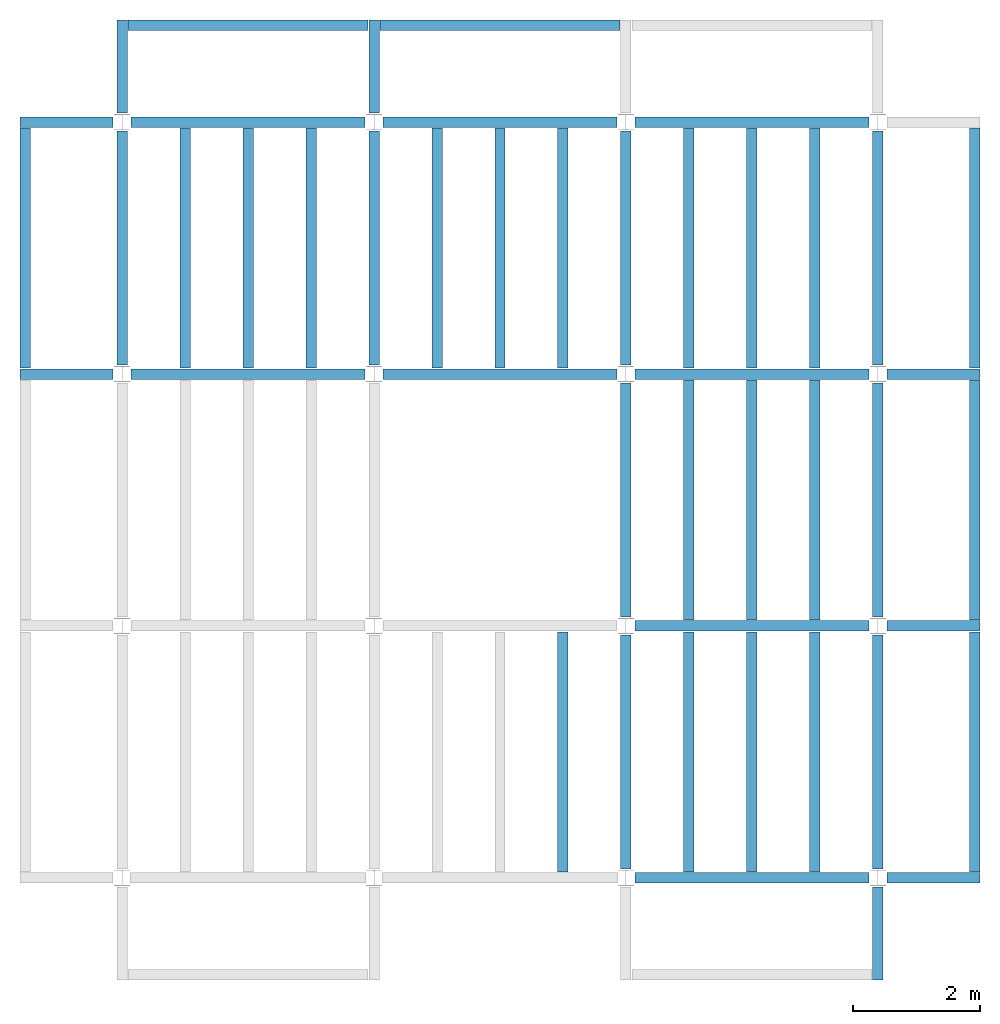
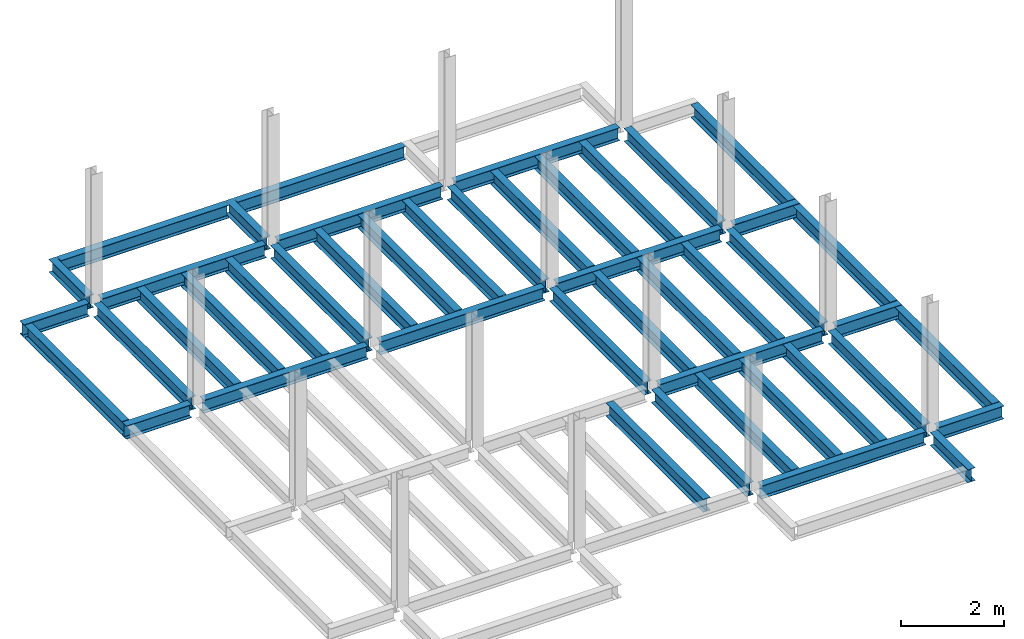
# One storey, part 2 of 3: 46 beams, 6 elements without a shape of their own.
"""IFC4 building model written with IfcOpenShell, lengths in feet."""

from ifc_helpers import new_model, entity, si_unit, converted_unit, derived_unit, direction, frame, origin, place, context, subcontext, project, spatial, line, arc, indexed_curve, outline, extrude, source, transform, mapped, material, type_object, type_shapes, element, aggregate, save


model = new_model("IFC4")

# Units and contexts
model_context = context("Model", 3, precision=0.0001, world=origin(), true_north=direction((6.123233995736766e-17, 1.0)))
plan_context = context("Plan", 3, precision=0.0001, world=origin(), true_north=direction((6.123233995736766e-17, 1.0)))
body_context = subcontext(model_context, "Body", "Model", "MODEL_VIEW")
ifc_project = project(units=[converted_unit("LENGTHUNIT", "FOOT", entity("IfcLengthMeasure", 0.3048), si_unit("LENGTHUNIT", "METRE"), dimensions=[1, 0, 0, 0, 0, 0, 0]), converted_unit("AREAUNIT", "SQUARE FOOT", entity("IfcAreaMeasure", 0.09290304), si_unit("AREAUNIT", "SQUARE_METRE"), dimensions=[2, 0, 0, 0, 0, 0, 0]), converted_unit("PLANEANGLEUNIT", "DEGREE", entity("IfcPlaneAngleMeasure", 0.017453292519943278), si_unit("PLANEANGLEUNIT", "RADIAN"), dimensions=[0, 0, 0, 0, 0, 0, 0]), converted_unit("VOLUMEUNIT", "CUBIC FOOT", entity("IfcVolumeMeasure", 0.028316846592000004), si_unit("VOLUMEUNIT", "CUBIC_METRE"), dimensions=[3, 0, 0, 0, 0, 0, 0]), si_unit("PRESSUREUNIT", "PASCAL"), derived_unit("MASSDENSITYUNIT", [(si_unit("MASSUNIT", "GRAM", prefix="KILO"), 1), (si_unit("LENGTHUNIT", "METRE"), -3)]), derived_unit("VAPORPERMEABILITYUNIT", [(si_unit("LENGTHUNIT", "METRE"), -1), (si_unit("TIMEUNIT", "SECOND"), 1)]), derived_unit("USERDEFINED", [(si_unit("MASSUNIT", "GRAM", prefix="KILO"), 1), (si_unit("LENGTHUNIT", "METRE"), 3), (si_unit("TIMEUNIT", "SECOND"), -3), (si_unit("ELECTRICCURRENTUNIT", "AMPERE"), -2)]), derived_unit("MODULUSOFELASTICITYUNIT", [(si_unit("MASSUNIT", "GRAM", prefix="KILO"), 1), (si_unit("LENGTHUNIT", "METRE"), -1), (si_unit("TIMEUNIT", "SECOND"), -2)]), derived_unit("THERMALEXPANSIONCOEFFICIENTUNIT", [(si_unit("THERMODYNAMICTEMPERATUREUNIT", "KELVIN"), -1)]), derived_unit("SPECIFICHEATCAPACITYUNIT", [(si_unit("TIMEUNIT", "SECOND"), -2), (si_unit("THERMODYNAMICTEMPERATUREUNIT", "KELVIN"), -1), (si_unit("LENGTHUNIT", "METRE"), 2)]), derived_unit("THERMALCONDUCTANCEUNIT", [(si_unit("MASSUNIT", "GRAM", prefix="KILO"), 1), (si_unit("TIMEUNIT", "SECOND"), -3), (si_unit("THERMODYNAMICTEMPERATUREUNIT", "KELVIN"), -1), (si_unit("LENGTHUNIT", "METRE"), 1)])], contexts=[model_context, plan_context])

# Site, building, storey
site_placement = place(None, origin())
site = spatial("IfcSite", under=ifc_project, at=site_placement, CompositionType="ELEMENT")
building_placement = place(site_placement, origin())
building = spatial("IfcBuilding", under=site, at=building_placement, CompositionType="ELEMENT")
storey_placement = place(building_placement, frame((0.0, 0.0, 79.875)))
storey = spatial("IfcBuildingStorey", under=building, at=storey_placement, Name="STR 09", CompositionType="ELEMENT", Elevation=79.875)

# Beams
ifc_material = material(Name="Steel ASTM A992", Category="Metal")
beam_type_1 = type_object("IfcBeamType", Name="W12X26", PredefinedType="JOIST", material=ifc_material)
shared_shape_1 = source(origin(), body_context, "Body", "SweptSolid", [
    extrude(outline(indexed_curve([(-0.27041666666666714, -0.47666666666666574), (-0.27041666666666714, -0.5083333333333351), (0.2704166666666669, -0.5083333333333351), (0.2704166666666669, -0.47666666666666574), (0.03458333333333309, -0.47666666666666574), (0.016905663803669493, -0.46934433619632937), (0.009583333333333202, -0.4516666666666659), (0.0095833333333332, 0.45166666666666705), (0.01690566380366948, 0.4693443361963307), (0.03458333333333325, 0.4766666666666671), (0.2704166666666669, 0.4766666666666671), (0.2704166666666669, 0.5083333333333312), (-0.2704166666666655, 0.5083333333333312), (-0.2704166666666655, 0.4766666666666671), (-0.034583333333333514, 0.47666666666666707), (-0.016905663803669865, 0.46934433619633054), (-0.009583333333333737, 0.45166666666666694), (-0.009583333333333735, -0.4516666666666658), (-0.01690566380367013, -0.4693443361963295), (-0.03458333333333368, -0.47666666666666574)], segments=[line(1, 2, 3, 4, 5), arc(5, 6, 7), line(7, 8), arc(8, 9, 10), line(10, 11, 12, 13, 14, 15), arc(15, 16, 17), line(17, 18), arc(18, 19, 20), line(20, 1)], self_intersect=False)), frame((-6.103346456692914, 0.0, 0.0), z_axis=(-1.0, 0.0, 0.0), x_axis=(0.0, -1.0, 0.0)), (0.0, 0.0, -1.0), 12.083333333333323),
])
type_shapes(beam_type_1, [shared_shape_1])
for number, where, name in (
    (1, (6.561679790026307, 39.0, -0.50833333333334), "W12X26"),
    (2, (6.561679790026288, 26.0, -0.50833333333334), "W12X26"),
):
    element("IfcBeam", number, at=place(storey_placement, frame(where)), inside=storey, type_object=beam_type_1, material=ifc_material, Name=name, ObjectType="W Shapes:W12X26", PredefinedType="JOIST", context=body_context, shape_type="MappedRepresentation", body=[
        mapped(shared_shape_1, transform((0.0, 0.0, 0.0), scale=1.0)),
    ])
for number, where, z_axis, x_axis, name in (
    (3, (39.0, 6.56167979002612, -0.50833333333334), (0.0, 0.0, 1.0), (0.0, 1.0, 0.0), "W12X26"),
    (4, (26.0, 6.561679790026162, -0.50833333333334), (0.0, 0.0, 1.0), (0.0, 1.0, 0.0), "W12X26"),
):
    element("IfcBeam", number, at=place(storey_placement, frame(where, z_axis=z_axis, x_axis=x_axis)), inside=storey, type_object=beam_type_1, material=ifc_material, Name=name, ObjectType="W Shapes:W12X26", PredefinedType="JOIST", context=body_context, shape_type="MappedRepresentation", body=[
        mapped(shared_shape_1, transform((0.0, 0.0, 0.0), scale=1.0)),
    ])
beam_type_2 = type_object("IfcBeamType", Name="W12X26", PredefinedType="JOIST", material=ifc_material)
shared_shape_2 = source(origin(), body_context, "Body", "SweptSolid", [
    extrude(outline(indexed_curve([(-0.27041666666666714, -0.47666666666666574), (-0.27041666666666714, -0.5083333333333351), (0.2704166666666669, -0.5083333333333351), (0.2704166666666669, -0.47666666666666574), (0.03458333333333309, -0.47666666666666574), (0.016905663803669493, -0.46934433619632937), (0.009583333333333202, -0.4516666666666659), (0.0095833333333332, 0.45166666666666705), (0.01690566380366948, 0.4693443361963307), (0.03458333333333325, 0.4766666666666671), (0.2704166666666669, 0.4766666666666671), (0.2704166666666669, 0.5083333333333312), (-0.2704166666666655, 0.5083333333333312), (-0.2704166666666655, 0.4766666666666671), (-0.034583333333333514, 0.47666666666666707), (-0.016905663803669865, 0.46934433619633054), (-0.009583333333333737, 0.45166666666666694), (-0.009583333333333735, -0.4516666666666658), (-0.01690566380367013, -0.4693443361963295), (-0.03458333333333368, -0.47666666666666574)], segments=[line(1, 2, 3, 4, 5), arc(5, 6, 7), line(7, 8), arc(8, 9, 10), line(10, 11, 12, 13, 14, 15), arc(15, 16, 17), line(17, 18), arc(18, 19, 20), line(20, 1)], self_intersect=False)), frame((-6.226706036745409, 0.0, 0.0), z_axis=(-1.0, 0.0, 0.0), x_axis=(0.0, -1.0, 0.0)), (0.0, 0.0, -1.0), 12.08333333333333),
])
type_shapes(beam_type_2, [shared_shape_2])
for number, where, name in (
    (5, (19.685039370078798, 39.0, -0.50833333333334), "W12X26"),
    (6, (19.68503937007878, 26.0, -0.50833333333334), "W12X26"),
):
    element("IfcBeam", number, at=place(storey_placement, frame(where)), inside=storey, type_object=beam_type_2, material=ifc_material, Name=name, ObjectType="W Shapes:W12X26", PredefinedType="JOIST", context=body_context, shape_type="MappedRepresentation", body=[
        mapped(shared_shape_2, transform((0.0, 0.0, 0.0), scale=1.0)),
    ])
for number, where, z_axis, x_axis, name in (
    (7, (39.0, 19.685039370078613, -0.50833333333334), (0.0, 0.0, 1.0), (0.0, 1.0, 0.0), "W12X26"),
    (8, (26.0, 19.685039370078655, -0.50833333333334), (0.0, 0.0, 1.0), (0.0, 1.0, 0.0), "W12X26"),
):
    element("IfcBeam", number, at=place(storey_placement, frame(where, z_axis=z_axis, x_axis=x_axis)), inside=storey, type_object=beam_type_2, material=ifc_material, Name=name, ObjectType="W Shapes:W12X26", PredefinedType="JOIST", context=body_context, shape_type="MappedRepresentation", body=[
        mapped(shared_shape_2, transform((0.0, 0.0, 0.0), scale=1.0)),
    ])

# Assembly, beams
assembly_1_placement = place(storey_placement, origin())
assembly_1 = element("IfcElementAssembly", 9, at=assembly_1_placement, inside=storey, Name="Structural Framing System", ObjectType="Structural Beam System:Structural Framing System", AssemblyPlace="NOTDEFINED", PredefinedType="BEAM_GRID")
beam_type_3 = type_object("IfcBeamType", Name="W12X26", PredefinedType="JOIST", material=ifc_material)
shared_shape_3 = source(origin(), body_context, "Body", "SweptSolid", [
    extrude(outline(indexed_curve([(-0.27041666666666714, -0.47666666666666574), (-0.27041666666666714, -0.5083333333333351), (0.2704166666666669, -0.5083333333333351), (0.2704166666666669, -0.47666666666666574), (0.03458333333333309, -0.47666666666666574), (0.016905663803669493, -0.46934433619632937), (0.009583333333333202, -0.4516666666666659), (0.0095833333333332, 0.45166666666666705), (0.01690566380366948, 0.4693443361963307), (0.03458333333333325, 0.4766666666666671), (0.2704166666666669, 0.4766666666666671), (0.2704166666666669, 0.5083333333333312), (-0.2704166666666655, 0.5083333333333312), (-0.2704166666666655, 0.4766666666666671), (-0.034583333333333514, 0.47666666666666707), (-0.016905663803669865, 0.46934433619633054), (-0.009583333333333737, 0.45166666666666694), (-0.009583333333333735, -0.4516666666666658), (-0.01690566380367013, -0.4693443361963295), (-0.03458333333333368, -0.47666666666666574)], segments=[line(1, 2, 3, 4, 5), arc(5, 6, 7), line(7, 8), arc(8, 9, 10), line(10, 11, 12, 13, 14, 15), arc(15, 16, 17), line(17, 18), arc(18, 19, 20), line(20, 1)], self_intersect=False)), frame((-6.187916666666566, 0.0, 0.0), z_axis=(-1.0, 0.0, 0.0), x_axis=(0.0, -1.0, 0.0)), (0.0, 0.0, -1.0), 12.375833333333075),
])
type_shapes(beam_type_3, [shared_shape_3])
beam_1_placement = place(assembly_1_placement, frame((3.250000000000073, 32.49999999999969, -0.50833333333334), z_axis=(0.0, 0.0, 1.0), x_axis=(0.0, 1.0, 0.0)))
beam_1 = element("IfcBeam", 10, at=beam_1_placement, type_object=beam_type_3, material=ifc_material, Name="W12X26", ObjectType="W Shapes:W12X26", PredefinedType="JOIST", context=body_context, shape_type="MappedRepresentation", body=[
    mapped(shared_shape_3, transform((0.0, 0.0, 0.0), scale=1.0)),
])
beam_2_placement = place(assembly_1_placement, frame((6.500000000000094, 32.49999999999967, -0.50833333333334), z_axis=(0.0, 0.0, 1.0), x_axis=(0.0, 1.0, 0.0)))
beam_2 = element("IfcBeam", 11, at=beam_2_placement, type_object=beam_type_3, material=ifc_material, Name="W12X26", ObjectType="W Shapes:W12X26", PredefinedType="JOIST", context=body_context, shape_type="MappedRepresentation", body=[
    mapped(shared_shape_3, transform((0.0, 0.0, 0.0), scale=1.0)),
])
beam_3_placement = place(assembly_1_placement, frame((9.750000000000115, 32.49999999999966, -0.50833333333334), z_axis=(0.0, 0.0, 1.0), x_axis=(0.0, 1.0, 0.0)))
beam_3 = element("IfcBeam", 12, at=beam_3_placement, type_object=beam_type_3, material=ifc_material, Name="W12X26", ObjectType="W Shapes:W12X26", PredefinedType="JOIST", context=body_context, shape_type="MappedRepresentation", body=[
    mapped(shared_shape_3, transform((0.0, 0.0, 0.0), scale=1.0)),
])
aggregate(assembly_1, [beam_1, beam_2, beam_3])

# Assembly, beam
assembly_2_placement = place(storey_placement, origin())
assembly_2 = element("IfcElementAssembly", 13, at=assembly_2_placement, inside=storey, Name="Structural Framing System", ObjectType="Structural Beam System:Structural Framing System", AssemblyPlace="NOTDEFINED", PredefinedType="BEAM_GRID")
beam_4_placement = place(assembly_2_placement, frame((22.750000000000103, 6.499999999999801, -0.50833333333334), z_axis=(0.0, 0.0, 1.0), x_axis=(0.0, 1.0, 0.0)))
beam_4 = element("IfcBeam", 14, at=beam_4_placement, type_object=beam_type_3, material=ifc_material, Name="W12X26", ObjectType="W Shapes:W12X26", PredefinedType="JOIST", context=body_context, shape_type="MappedRepresentation", body=[
    mapped(shared_shape_3, transform((0.0, 0.0, 0.0), scale=1.0)),
])
aggregate(assembly_2, [beam_4])

# Assembly, beams
assembly_3_placement = place(storey_placement, origin())
assembly_3 = element("IfcElementAssembly", 15, at=assembly_3_placement, inside=storey, Name="Structural Framing System", ObjectType="Structural Beam System:Structural Framing System", AssemblyPlace="NOTDEFINED", PredefinedType="BEAM_GRID")
beam_5_placement = place(assembly_3_placement, frame((16.25000000000014, 32.499999999999645, -0.50833333333334), z_axis=(0.0, 0.0, 1.0), x_axis=(0.0, 1.0, 0.0)))
beam_5 = element("IfcBeam", 16, at=beam_5_placement, type_object=beam_type_3, material=ifc_material, Name="W12X26", ObjectType="W Shapes:W12X26", PredefinedType="JOIST", context=body_context, shape_type="MappedRepresentation", body=[
    mapped(shared_shape_3, transform((0.0, 0.0, 0.0), scale=1.0)),
])
beam_6_placement = place(assembly_3_placement, frame((19.50000000000014, 32.49999999999963, -0.50833333333334), z_axis=(0.0, 0.0, 1.0), x_axis=(0.0, 1.0, 0.0)))
beam_6 = element("IfcBeam", 17, at=beam_6_placement, type_object=beam_type_3, material=ifc_material, Name="W12X26", ObjectType="W Shapes:W12X26", PredefinedType="JOIST", context=body_context, shape_type="MappedRepresentation", body=[
    mapped(shared_shape_3, transform((0.0, 0.0, 0.0), scale=1.0)),
])
beam_7_placement = place(assembly_3_placement, frame((22.750000000000142, 32.499999999999616, -0.50833333333334), z_axis=(0.0, 0.0, 1.0), x_axis=(0.0, 1.0, 0.0)))
beam_7 = element("IfcBeam", 18, at=beam_7_placement, type_object=beam_type_3, material=ifc_material, Name="W12X26", ObjectType="W Shapes:W12X26", PredefinedType="JOIST", context=body_context, shape_type="MappedRepresentation", body=[
    mapped(shared_shape_3, transform((0.0, 0.0, 0.0), scale=1.0)),
])
aggregate(assembly_3, [beam_5, beam_6, beam_7])

assembly_4_placement = place(storey_placement, origin())
assembly_4 = element("IfcElementAssembly", 19, at=assembly_4_placement, inside=storey, Name="Structural Framing System", ObjectType="Structural Beam System:Structural Framing System", AssemblyPlace="NOTDEFINED", PredefinedType="BEAM_GRID")
beam_8_placement = place(assembly_4_placement, frame((29.2500000000001, 6.49999999999975, -0.50833333333334), z_axis=(0.0, 0.0, 1.0), x_axis=(0.0, 1.0, 0.0)))
beam_8 = element("IfcBeam", 20, at=beam_8_placement, type_object=beam_type_3, material=ifc_material, Name="W12X26", ObjectType="W Shapes:W12X26", PredefinedType="JOIST", context=body_context, shape_type="MappedRepresentation", body=[
    mapped(shared_shape_3, transform((0.0, 0.0, 0.0), scale=1.0)),
])
beam_9_placement = place(assembly_4_placement, frame((32.5000000000001, 6.499999999999737, -0.50833333333334), z_axis=(0.0, 0.0, 1.0), x_axis=(0.0, 1.0, 0.0)))
beam_9 = element("IfcBeam", 21, at=beam_9_placement, type_object=beam_type_3, material=ifc_material, Name="W12X26", ObjectType="W Shapes:W12X26", PredefinedType="JOIST", context=body_context, shape_type="MappedRepresentation", body=[
    mapped(shared_shape_3, transform((0.0, 0.0, 0.0), scale=1.0)),
])
beam_10_placement = place(assembly_4_placement, frame((35.7500000000001, 6.499999999999728, -0.50833333333334), z_axis=(0.0, 0.0, 1.0), x_axis=(0.0, 1.0, 0.0)))
beam_10 = element("IfcBeam", 22, at=beam_10_placement, type_object=beam_type_3, material=ifc_material, Name="W12X26", ObjectType="W Shapes:W12X26", PredefinedType="JOIST", context=body_context, shape_type="MappedRepresentation", body=[
    mapped(shared_shape_3, transform((0.0, 0.0, 0.0), scale=1.0)),
])
aggregate(assembly_4, [beam_8, beam_9, beam_10])

assembly_5_placement = place(storey_placement, origin())
assembly_5 = element("IfcElementAssembly", 23, at=assembly_5_placement, inside=storey, Name="Structural Framing System", ObjectType="Structural Beam System:Structural Framing System", AssemblyPlace="NOTDEFINED", PredefinedType="BEAM_GRID")
beam_11_placement = place(assembly_5_placement, frame((29.25000000000012, 19.499999999999595, -0.50833333333334), z_axis=(0.0, 0.0, 1.0), x_axis=(0.0, 1.0, 0.0)))
beam_11 = element("IfcBeam", 24, at=beam_11_placement, type_object=beam_type_3, material=ifc_material, Name="W12X26", ObjectType="W Shapes:W12X26", PredefinedType="JOIST", context=body_context, shape_type="MappedRepresentation", body=[
    mapped(shared_shape_3, transform((0.0, 0.0, 0.0), scale=1.0)),
])
beam_12_placement = place(assembly_5_placement, frame((32.500000000000114, 19.49999999999958, -0.50833333333334), z_axis=(0.0, 0.0, 1.0), x_axis=(0.0, 1.0, 0.0)))
beam_12 = element("IfcBeam", 25, at=beam_12_placement, type_object=beam_type_3, material=ifc_material, Name="W12X26", ObjectType="W Shapes:W12X26", PredefinedType="JOIST", context=body_context, shape_type="MappedRepresentation", body=[
    mapped(shared_shape_3, transform((0.0, 0.0, 0.0), scale=1.0)),
])
beam_13_placement = place(assembly_5_placement, frame((35.750000000000114, 19.499999999999574, -0.50833333333334), z_axis=(0.0, 0.0, 1.0), x_axis=(0.0, 1.0, 0.0)))
beam_13 = element("IfcBeam", 26, at=beam_13_placement, type_object=beam_type_3, material=ifc_material, Name="W12X26", ObjectType="W Shapes:W12X26", PredefinedType="JOIST", context=body_context, shape_type="MappedRepresentation", body=[
    mapped(shared_shape_3, transform((0.0, 0.0, 0.0), scale=1.0)),
])
aggregate(assembly_5, [beam_11, beam_12, beam_13])

assembly_6_placement = place(storey_placement, origin())
assembly_6 = element("IfcElementAssembly", 27, at=assembly_6_placement, inside=storey, Name="Structural Framing System", ObjectType="Structural Beam System:Structural Framing System", AssemblyPlace="NOTDEFINED", PredefinedType="BEAM_GRID")
beam_14_placement = place(assembly_6_placement, frame((29.250000000000142, 32.4999999999996, -0.50833333333334), z_axis=(0.0, 0.0, 1.0), x_axis=(0.0, 1.0, 0.0)))
beam_14 = element("IfcBeam", 28, at=beam_14_placement, type_object=beam_type_3, material=ifc_material, Name="W12X26", ObjectType="W Shapes:W12X26", PredefinedType="JOIST", context=body_context, shape_type="MappedRepresentation", body=[
    mapped(shared_shape_3, transform((0.0, 0.0, 0.0), scale=1.0)),
])
beam_15_placement = place(assembly_6_placement, frame((32.50000000000014, 32.49999999999959, -0.50833333333334), z_axis=(0.0, 0.0, 1.0), x_axis=(0.0, 1.0, 0.0)))
beam_15 = element("IfcBeam", 29, at=beam_15_placement, type_object=beam_type_3, material=ifc_material, Name="W12X26", ObjectType="W Shapes:W12X26", PredefinedType="JOIST", context=body_context, shape_type="MappedRepresentation", body=[
    mapped(shared_shape_3, transform((0.0, 0.0, 0.0), scale=1.0)),
])
beam_16_placement = place(assembly_6_placement, frame((35.75000000000014, 32.499999999999574, -0.50833333333334), z_axis=(0.0, 0.0, 1.0), x_axis=(0.0, 1.0, 0.0)))
beam_16 = element("IfcBeam", 30, at=beam_16_placement, type_object=beam_type_3, material=ifc_material, Name="W12X26", ObjectType="W Shapes:W12X26", PredefinedType="JOIST", context=body_context, shape_type="MappedRepresentation", body=[
    mapped(shared_shape_3, transform((0.0, 0.0, 0.0), scale=1.0)),
])
aggregate(assembly_6, [beam_14, beam_15, beam_16])

# Beams
for number, where, z_axis, x_axis, name in (
    (31, (-5.0, 32.4999999999997, -0.50833333333334), (0.0, 0.0, 1.0), (0.0, 1.0, 0.0), "W12X26"),
    (32, (44.0, 6.4999999999997, -0.50833333333334), (0.0, 0.0, 1.0), (0.0, 1.0, 0.0), "W12X26"),
    (33, (44.0, 19.499999999999545, -0.50833333333334), (0.0, 0.0, 1.0), (0.0, 1.0, 0.0), "W12X26"),
    (34, (44.0, 32.499999999999545, -0.50833333333334), (0.0, 0.0, 1.0), (0.0, 1.0, 0.0), "W12X26"),
):
    element("IfcBeam", number, at=place(storey_placement, frame(where, z_axis=z_axis, x_axis=x_axis)), inside=storey, type_object=beam_type_3, material=ifc_material, Name=name, ObjectType="W Shapes:W12X26", PredefinedType="JOIST", context=body_context, shape_type="MappedRepresentation", body=[
        mapped(shared_shape_3, transform((0.0, 0.0, 0.0), scale=1.0)),
    ])
beam_17_placement = place(storey_placement, frame((6.5000000000001625, 44.0, -0.50833333333334)))
element("IfcBeam", 35, at=beam_17_placement, inside=storey, type_object=beam_type_3, material=ifc_material, Name="W Shapes:W12X26", ObjectType="W Shapes:W12X26", PredefinedType="JOIST", context=body_context, shape_type="MappedRepresentation", body=[
    mapped(shared_shape_3, transform((0.0, 0.0, 0.0), scale=1.0)),
])
beam_type_4 = type_object("IfcBeamType", Name="W12X26", PredefinedType="JOIST", material=ifc_material)
shared_shape_4 = source(origin(), body_context, "Body", "SweptSolid", [
    extrude(outline(indexed_curve([(-0.27041666666666714, -0.47666666666666574), (-0.27041666666666714, -0.5083333333333351), (0.2704166666666669, -0.5083333333333351), (0.2704166666666669, -0.47666666666666574), (0.03458333333333309, -0.47666666666666574), (0.016905663803669493, -0.46934433619632937), (0.009583333333333202, -0.4516666666666659), (0.0095833333333332, 0.45166666666666705), (0.01690566380366948, 0.4693443361963307), (0.03458333333333325, 0.4766666666666671), (0.2704166666666669, 0.4766666666666671), (0.2704166666666669, 0.5083333333333312), (-0.2704166666666655, 0.5083333333333312), (-0.2704166666666655, 0.4766666666666671), (-0.034583333333333514, 0.47666666666666707), (-0.016905663803669865, 0.46934433619633054), (-0.009583333333333737, 0.45166666666666694), (-0.009583333333333735, -0.4516666666666658), (-0.01690566380367013, -0.4693443361963295), (-0.03458333333333368, -0.47666666666666574)], segments=[line(1, 2, 3, 4, 5), arc(5, 6, 7), line(7, 8), arc(8, 9, 10), line(10, 11, 12, 13, 14, 15), arc(15, 16, 17), line(17, 18), arc(18, 19, 20), line(20, 1)], self_intersect=False)), frame((-6.165026246719308, 0.0, 0.0), z_axis=(-1.0, 0.0, 0.0), x_axis=(0.0, -1.0, 0.0)), (0.0, 0.0, -1.0), 12.08333333333334),
])
type_shapes(beam_type_4, [shared_shape_4])
for number, where, name in (
    (36, (32.6233595800526, 39.0, -0.50833333333334), "W12X26"),
    (37, (32.62335958005258, 26.0, -0.50833333333334), "W12X26"),
    (38, (32.62335958005255, 13.0, -0.50833333333334), "W12X26"),
):
    element("IfcBeam", number, at=place(storey_placement, frame(where)), inside=storey, type_object=beam_type_4, material=ifc_material, Name=name, ObjectType="W Shapes:W12X26", PredefinedType="JOIST", context=body_context, shape_type="MappedRepresentation", body=[
        mapped(shared_shape_4, transform((0.0, 0.0, 0.0), scale=1.0)),
    ])
for number, where, z_axis, x_axis, name in (
    (39, (39.0, 32.62335958005221, -0.50833333333334), (0.0, 0.0, 1.0), (0.0, 1.0, 0.0), "W12X26"),
    (40, (26.0, 32.62335958005225, -0.50833333333334), (0.0, 0.0, 1.0), (0.0, 1.0, 0.0), "W12X26"),
    (41, (13.0, 32.623359580052295, -0.50833333333334), (0.0, 0.0, 1.0), (0.0, 1.0, 0.0), "W12X26"),
    (42, (0.0, 32.62335958005234, -0.50833333333334), (0.0, 0.0, 1.0), (0.0, 1.0, 0.0), "W12X26"),
):
    element("IfcBeam", number, at=place(storey_placement, frame(where, z_axis=z_axis, x_axis=x_axis)), inside=storey, type_object=beam_type_4, material=ifc_material, Name=name, ObjectType="W Shapes:W12X26", PredefinedType="JOIST", context=body_context, shape_type="MappedRepresentation", body=[
        mapped(shared_shape_4, transform((0.0, 0.0, 0.0), scale=1.0)),
    ])
beam_type_5 = type_object("IfcBeamType", Name="W12X26", PredefinedType="JOIST", material=ifc_material)
shared_shape_5 = source(origin(), body_context, "Body", "SweptSolid", [
    extrude(outline(indexed_curve([(-0.27041666666666714, -0.47666666666666574), (-0.27041666666666714, -0.5083333333333351), (0.2704166666666669, -0.5083333333333351), (0.2704166666666669, -0.47666666666666574), (0.03458333333333309, -0.47666666666666574), (0.016905663803669493, -0.46934433619632937), (0.009583333333333202, -0.4516666666666659), (0.0095833333333332, 0.45166666666666705), (0.01690566380366948, 0.4693443361963307), (0.03458333333333325, 0.4766666666666671), (0.2704166666666669, 0.4766666666666671), (0.2704166666666669, 0.5083333333333312), (-0.2704166666666655, 0.5083333333333312), (-0.2704166666666655, 0.4766666666666671), (-0.034583333333333514, 0.47666666666666707), (-0.016905663803669865, 0.46934433619633054), (-0.009583333333333737, 0.45166666666666694), (-0.009583333333333735, -0.4516666666666658), (-0.01690566380367013, -0.4693443361963295), (-0.03458333333333368, -0.47666666666666574)], segments=[line(1, 2, 3, 4, 5), arc(5, 6, 7), line(7, 8), arc(8, 9, 10), line(10, 11, 12, 13, 14, 15), arc(15, 16, 17), line(17, 18), arc(18, 19, 20), line(20, 1)], self_intersect=False)), frame((-6.0416666666667105, 0.0, 0.0), z_axis=(-1.0, 0.0, 0.0), x_axis=(0.0, -1.0, 0.0)), (0.0, 0.0, -1.0), 12.08333333333342),
])
type_shapes(beam_type_5, [shared_shape_5])
beam_18_placement = place(storey_placement, frame((32.500000000000085, 0.0, -0.50833333333334)))
element("IfcBeam", 43, at=beam_18_placement, inside=storey, type_object=beam_type_5, material=ifc_material, Name="W12X26", ObjectType="W Shapes:W12X26", PredefinedType="JOIST", context=body_context, shape_type="MappedRepresentation", body=[
    mapped(shared_shape_5, transform((0.0, 0.0, 0.0), scale=1.0)),
])
beam_type_6 = type_object("IfcBeamType", Name="W12X26", PredefinedType="JOIST", material=ifc_material)
shared_shape_6 = source(origin(), body_context, "Body", "SweptSolid", [
    extrude(outline(indexed_curve([(0.47666666666666574, -0.2704166666666672), (0.5083333333333351, -0.2704166666666672), (0.5083333333333351, 0.27041666666666686), (0.47666666666666574, 0.27041666666666686), (0.47666666666666574, 0.03458333333333307), (0.46934433619632937, 0.016905663803669473), (0.4516666666666659, 0.00958333333333318), (-0.45166666666666705, 0.00958333333333318), (-0.4693443361963307, 0.01690566380366946), (-0.4766666666666671, 0.03458333333333323), (-0.4766666666666671, 0.27041666666666686), (-0.5083333333333312, 0.27041666666666686), (-0.5083333333333312, -0.27041666666666553), (-0.4766666666666671, -0.27041666666666553), (-0.47666666666666707, -0.034583333333333535), (-0.46934433619633054, -0.016905663803669885), (-0.45166666666666694, -0.00958333333333376), (0.4516666666666658, -0.009583333333333756), (0.4693443361963295, -0.01690566380367015), (0.47666666666666574, -0.0345833333333337)], segments=[line(1, 2, 3, 4, 5), arc(5, 6, 7), line(7, 8), arc(8, 9, 10), line(10, 11, 12, 13, 14, 15), arc(15, 16, 17), line(17, 18), arc(18, 19, 20), line(20, 1)], self_intersect=False)), frame((-2.0416666666666208, 0.0, 0.0), z_axis=(1.0, 0.0, 0.0), x_axis=(0.0, 0.0, -1.0)), (0.0, 0.0, 1.0), 4.812083333333336),
])
type_shapes(beam_type_6, [shared_shape_6])
for number, where, z_axis, x_axis, name in (
    (44, (-2.4999999999998104, 39.0, -0.50833333333334), (0.0, 0.0, 1.0), (-1.0, 0.0, 0.0), "W12X26"),
    (45, (39.0, -2.50000000000058, -0.50833333333334), (0.0, 0.0, 1.0), (0.0, -1.0, 0.0), "W12X26"),
    (46, (-2.4999999999998317, 26.0, -0.50833333333334), (0.0, 0.0, 1.0), (-1.0, 0.0, 0.0), "W12X26"),
):
    element("IfcBeam", number, at=place(storey_placement, frame(where, z_axis=z_axis, x_axis=x_axis)), inside=storey, type_object=beam_type_6, material=ifc_material, Name=name, ObjectType="W Shapes:W12X26", PredefinedType="JOIST", context=body_context, shape_type="MappedRepresentation", body=[
        mapped(shared_shape_6, transform((0.0, 0.0, 0.0), scale=1.0)),
    ])
beam_type_7 = type_object("IfcBeamType", Name="W12X26", PredefinedType="JOIST", material=ifc_material)
shared_shape_7 = source(origin(), body_context, "Body", "SweptSolid", [
    extrude(outline(indexed_curve([(0.47666666666666574, -0.2704166666666672), (0.5083333333333351, -0.2704166666666672), (0.5083333333333351, 0.27041666666666686), (0.47666666666666574, 0.27041666666666686), (0.47666666666666574, 0.03458333333333307), (0.46934433619632937, 0.016905663803669473), (0.4516666666666659, 0.00958333333333318), (-0.45166666666666705, 0.00958333333333318), (-0.4693443361963307, 0.01690566380366946), (-0.4766666666666671, 0.03458333333333323), (-0.4766666666666671, 0.27041666666666686), (-0.5083333333333312, 0.27041666666666686), (-0.5083333333333312, -0.27041666666666553), (-0.4766666666666671, -0.27041666666666553), (-0.47666666666666707, -0.034583333333333535), (-0.46934433619633054, -0.016905663803669885), (-0.45166666666666694, -0.00958333333333376), (0.4516666666666658, -0.009583333333333756), (0.4693443361963295, -0.01690566380367015), (0.47666666666666574, -0.0345833333333337)], segments=[line(1, 2, 3, 4, 5), arc(5, 6, 7), line(7, 8), arc(8, 9, 10), line(10, 11, 12, 13, 14, 15), arc(15, 16, 17), line(17, 18), arc(18, 19, 20), line(20, 1)], self_intersect=False)), frame((-2.77041666666672, 0.0, 0.0), z_axis=(1.0, 0.0, 0.0), x_axis=(0.0, 0.0, -1.0)), (0.0, 0.0, 1.0), 4.812083333333389),
])
type_shapes(beam_type_7, [shared_shape_7])
for number, where, z_axis, x_axis, name in (
    (47, (41.50000000000013, 26.0, -0.50833333333334), (0.0, 0.0, 1.0), (-1.0, 0.0, 0.0), "W12X26"),
    (48, (41.50000000000011, 13.0, -0.50833333333334), (0.0, 0.0, 1.0), (-1.0, 0.0, 0.0), "W12X26"),
    (49, (41.500000000000085, 0.0, -0.50833333333334), (0.0, 0.0, 1.0), (-1.0, 0.0, 0.0), "W12X26"),
    (50, (13.0, 41.49999999999965, -0.50833333333334), (0.0, 0.0, 1.0), (0.0, -1.0, 0.0), "W12X26"),
    (51, (0.0, 41.499999999999694, -0.50833333333334), (0.0, 0.0, 1.0), (0.0, -1.0, 0.0), "W12X26"),
):
    element("IfcBeam", number, at=place(storey_placement, frame(where, z_axis=z_axis, x_axis=x_axis)), inside=storey, type_object=beam_type_7, material=ifc_material, Name=name, ObjectType="W Shapes:W12X26", PredefinedType="JOIST", context=body_context, shape_type="MappedRepresentation", body=[
        mapped(shared_shape_7, transform((0.0, 0.0, 0.0), scale=1.0)),
    ])
beam_type_8 = type_object("IfcBeamType", Name="W12X26", PredefinedType="JOIST", material=ifc_material)
shared_shape_8 = source(origin(), body_context, "Body", "SweptSolid", [
    extrude(outline(indexed_curve([(0.47666666666666574, -0.2704166666666672), (0.5083333333333351, -0.2704166666666672), (0.5083333333333351, 0.27041666666666686), (0.47666666666666574, 0.27041666666666686), (0.47666666666666574, 0.03458333333333307), (0.46934433619632937, 0.016905663803669473), (0.4516666666666659, 0.00958333333333318), (-0.45166666666666705, 0.00958333333333318), (-0.4693443361963307, 0.01690566380366946), (-0.4766666666666671, 0.03458333333333323), (-0.4766666666666671, 0.27041666666666686), (-0.5083333333333312, 0.27041666666666686), (-0.5083333333333312, -0.27041666666666553), (-0.4766666666666671, -0.27041666666666553), (-0.47666666666666707, -0.034583333333333535), (-0.46934433619633054, -0.016905663803669885), (-0.45166666666666694, -0.00958333333333376), (0.4516666666666658, -0.009583333333333756), (0.4693443361963295, -0.01690566380367015), (0.47666666666666574, -0.0345833333333337)], segments=[line(1, 2, 3, 4, 5), arc(5, 6, 7), line(7, 8), arc(8, 9, 10), line(10, 11, 12, 13, 14, 15), arc(15, 16, 17), line(17, 18), arc(18, 19, 20), line(20, 1)], self_intersect=False)), frame((-6.187916666666685, 0.0, 0.0), z_axis=(1.0, 0.0, 0.0), x_axis=(0.0, 0.0, -1.0)), (0.0, 0.0, 1.0), 12.375833333333318),
])
type_shapes(beam_type_8, [shared_shape_8])
beam_19_placement = place(storey_placement, frame((19.500000000000142, 44.0, -0.50833333333334), z_axis=(0.0, 0.0, 1.0), x_axis=(-1.0, 0.0, 0.0)))
element("IfcBeam", 52, at=beam_19_placement, inside=storey, type_object=beam_type_8, material=ifc_material, Name="W Shapes:W12X26", ObjectType="W Shapes:W12X26", PredefinedType="JOIST", context=body_context, shape_type="MappedRepresentation", body=[
    mapped(shared_shape_8, transform((0.0, 0.0, 0.0), scale=1.0)),
])

save(model, "model.ifc")
